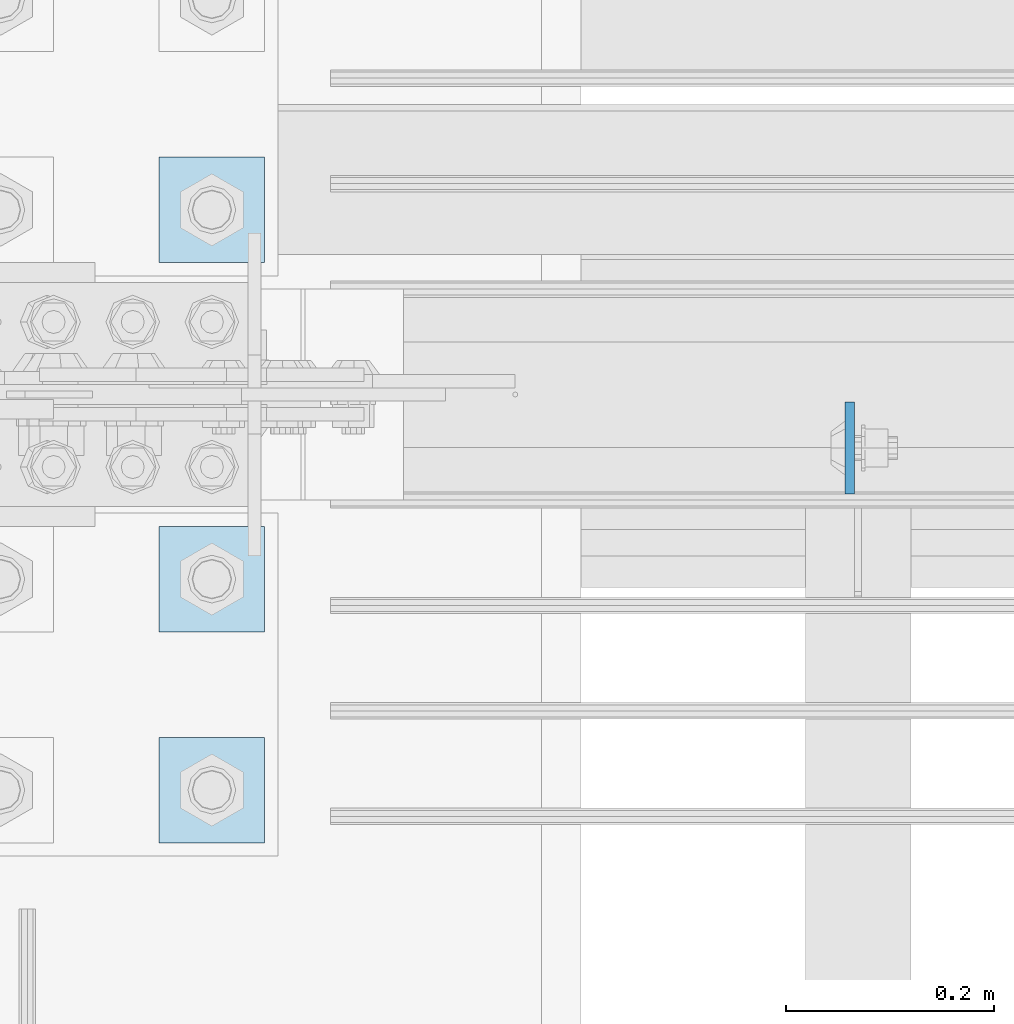
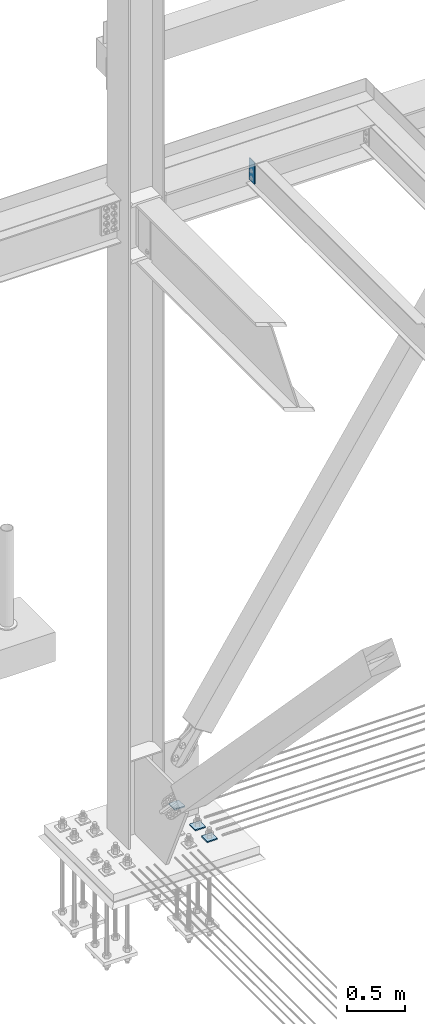
# One storey, part 3642 of 3843: 4 plates, 2 elements without a shape of their own.
"""IFC2X3 building model written with IfcOpenShell, lengths in millimetres."""

import ifcopenshell
import ifcopenshell.guid

model = None  # the IFC model being written
_history = None  # IfcOwnerHistory: only IFC2X3 demands one
_inside = {}  # id of a spatial element -> (the spatial element, [elements in it])
_under = {}  # id of a project, library or spatial element -> (it, [spatial elements below it])
_declared = {}  # id of a project -> (the project, [libraries it declares])
_typed = {}  # id of a type object -> (the type object, [elements of that type])
_made_of = {}  # id of a material, layer set ... -> (it, [elements and type objects made of it])


def new_model(schema):
    """Start an empty IFC model of exactly this schema.

    Asked for "IFC4X3", IfcOpenShell would pick the latest addendum, in which some entities
    have other attributes; the version numbers below select the first issue.
    IFC2X3 requires an IfcOwnerHistory on every rooted entity: one is made here for all.
    """
    global model, _history
    if schema == "IFC4X3":
        model = ifcopenshell.file(schema_version=(4, 3, 0, 0))
    else:
        model = ifcopenshell.file(schema=schema)
    _inside.clear()
    _under.clear()
    _declared.clear()
    _typed.clear()
    _made_of.clear()
    _history = None
    if model.schema == "IFC2X3":
        org = make("IfcOrganization", Name="unknown")
        user = make(
            "IfcPersonAndOrganization",
            ThePerson=make("IfcPerson", FamilyName="unknown"),
            TheOrganization=org,
        )
        app = make(
            "IfcApplication",
            ApplicationDeveloper=org,
            Version="unknown",
            ApplicationFullName="unknown",
            ApplicationIdentifier="unknown",
        )
        _history = make(
            "IfcOwnerHistory",
            OwningUser=user,
            OwningApplication=app,
            ChangeAction="ADDED",
            CreationDate=0,
        )
    return model


def make(cls, **values):
    """One entity of the class cls with the attributes given. An attribute that is None is left unset."""
    return model.create_entity(
        cls, **{name: value for name, value in values.items() if value is not None}
    )


def rooted(cls, **values):
    """An entity with a GlobalId (a new one), such as an element, a storey or a relation."""
    return make(cls, GlobalId=ifcopenshell.guid.new(), OwnerHistory=_history, **values)


def si_unit(unit_type, name, prefix=None):
    """IfcSIUnit, for example si_unit("LENGTHUNIT", "METRE", prefix="MILLI")."""
    return make("IfcSIUnit", UnitType=unit_type, Prefix=prefix, Name=name)


def assignment(units):
    """IfcUnitAssignment: the units of a project."""
    return None if units is None else make("IfcUnitAssignment", Units=units)


def point(xyz):
    """IfcCartesianPoint."""
    return None if xyz is None else make("IfcCartesianPoint", Coordinates=xyz)


def direction(xyz):
    """IfcDirection."""
    return None if xyz is None else make("IfcDirection", DirectionRatios=xyz)


def frame(location, z_axis=None, x_axis=None):
    """IfcAxis2Placement3D, a coordinate frame: its origin and axes. An axis left out is left unset."""
    return make(
        "IfcAxis2Placement3D",
        Location=point(location),
        Axis=direction(z_axis),
        RefDirection=direction(x_axis),
    )


def origin_with_axes():
    """The frame at (0, 0, 0) with the z axis (0, 0, 1) and the x axis (1, 0, 0) written out."""
    return frame((0.0, 0.0, 0.0), z_axis=(0.0, 0.0, 1.0), x_axis=(1.0, 0.0, 0.0))


def place(relative_to, where):
    """IfcLocalPlacement: puts the frame where relative to a parent placement (None: the world)."""
    return make(
        "IfcLocalPlacement", PlacementRelTo=relative_to, RelativePlacement=where
    )


def context(
    kind, dimensions, precision=None, world=None, true_north=None, identifier=None
):
    """IfcGeometricRepresentationContext, for example the 3D "Model" context."""
    return make(
        "IfcGeometricRepresentationContext",
        ContextIdentifier=identifier,
        ContextType=kind,
        CoordinateSpaceDimension=dimensions,
        Precision=precision,
        WorldCoordinateSystem=world,
        TrueNorth=true_north,
    )


def subcontext(parent, identifier, kind, view, scale=None):
    """IfcGeometricRepresentationSubContext, for example "Body" below "Model"."""
    return make(
        "IfcGeometricRepresentationSubContext",
        ContextIdentifier=identifier,
        ContextType=kind,
        ParentContext=parent,
        TargetScale=scale,
        TargetView=view,
    )


def project(units=None, contexts=None):
    """IfcProject with its units and contexts."""
    return rooted(
        "IfcProject",
        Name="project",
        RepresentationContexts=contexts,
        UnitsInContext=assignment(units),
    )


def spatial(cls, under=None, at=None, **own):
    """A site, building, storey or space (cls), placed at a placement, below another one or the project."""
    s = rooted(cls, ObjectPlacement=at, **own)
    if under is not None:
        _under.setdefault(under.id(), (under, []))[1].append(s)
    return s


def faces_of(points, faces, orient=None, outer=None):
    """IfcFace entities. A face is a list of loops; a loop is a list of indices into points, from 0.

    orient and outer hold one flag for each loop. By default every Orientation is true, the
    first loop of a face is its IfcFaceOuterBound and the others are IfcFaceBound.
    """
    made = []
    for i, loops in enumerate(faces):
        bounds = []
        for j, loop in enumerate(loops):
            is_outer = j == 0 if outer is None else outer[i][j]
            bounds.append(
                make(
                    "IfcFaceOuterBound" if is_outer else "IfcFaceBound",
                    Bound=make("IfcPolyLoop", Polygon=[points[k] for k in loop]),
                    Orientation=True if orient is None else orient[i][j],
                )
            )
        made.append(make("IfcFace", Bounds=bounds))
    return made


def faceted_brep(points, faces, orient=None, outer=None, voids=None):
    """IfcFacetedBrep: a solid bounded by flat faces; with voids (closed shells), ...WithVoids."""
    shared = [point(p) for p in points]
    hull = make("IfcClosedShell", CfsFaces=faces_of(shared, faces, orient, outer))
    if voids is None:
        return make("IfcFacetedBrep", Outer=hull)
    return make(
        "IfcFacetedBrepWithVoids",
        Outer=hull,
        Voids=[
            make(cls, CfsFaces=faces_of(shared, fs, o, b)) for cls, fs, o, b in voids
        ],
    )


def shape(context_of_items, identifier, shape_type, items):
    """IfcShapeRepresentation: the items that make up one representation, for example the "Body"."""
    return make(
        "IfcShapeRepresentation",
        ContextOfItems=context_of_items,
        RepresentationIdentifier=identifier,
        RepresentationType=shape_type,
        Items=items,
    )


def material(Name=None, Category=None):
    """IfcMaterial."""
    return make("IfcMaterial", Name=Name, Category=Category)


def made_of(thing, what):
    """Note that an element or type object is made of a material, layer set ...; save() writes the relation."""
    if what is not None:
        _made_of.setdefault(what.id(), (what, []))[1].append(thing)
    return thing


def type_object(cls, material=None, **own):
    """A type object (cls), such as IfcWallType, which elements share."""
    return made_of(rooted(cls, **own), material)


def element(
    cls,
    number,
    at=None,
    inside=None,
    cuts=None,
    type_object=None,
    material=None,
    context=None,
    identifier="Body",
    shape_type=None,
    held_by="IfcProductDefinitionShape",
    body=None,
    shapes=None,
    **own,
):
    """One element of the class cls, such as IfcWall. Its Tag is "e" and its number.

    at: its placement. inside: the storey or other place that contains it. cuts: it is an
    opening in that element (IfcRelVoidsElement). A single representation is given by context,
    identifier, shape_type and body (its items); several are given by shapes. held_by: the class
    of the entity that holds the representations. save() writes the other relations.
    """
    e = rooted(cls, Tag="e%d" % number, ObjectPlacement=at, **own)
    if body is not None:
        shapes = [shape(context, identifier, shape_type, body)]
    if shapes is not None:
        e.Representation = make(held_by, Representations=shapes)
    if inside is not None:
        _inside.setdefault(inside.id(), (inside, []))[1].append(e)
    if cuts is not None:
        rooted(
            "IfcRelVoidsElement", RelatingBuildingElement=cuts, RelatedOpeningElement=e
        )
    if type_object is not None:
        _typed.setdefault(type_object.id(), (type_object, []))[1].append(e)
    return made_of(e, material)


def aggregate(whole, parts):
    """IfcRelAggregates: a whole, such as a stair, and the parts it consists of."""
    return rooted("IfcRelAggregates", RelatingObject=whole, RelatedObjects=parts)


def save(model, path):
    """Write the relations noted so far, then the file.

    IfcRelAggregates (storeys below a building ...), IfcRelContainedInSpatialStructure (elements
    in a storey), IfcRelDefinesByType, IfcRelAssociatesMaterial and IfcRelDeclares: one each for
    every whole, place, type object, material and project.
    """
    for whole, parts in _under.values():
        aggregate(whole, parts)
    for where, things in _inside.values():
        rooted(
            "IfcRelContainedInSpatialStructure",
            RelatedElements=things,
            RelatingStructure=where,
        )
    for kind, things in _typed.values():
        rooted("IfcRelDefinesByType", RelatedObjects=things, RelatingType=kind)
    for what, things in _made_of.values():
        rooted("IfcRelAssociatesMaterial", RelatedObjects=things, RelatingMaterial=what)
    for by, libraries in _declared.values():
        rooted("IfcRelDeclares", RelatingContext=by, RelatedDefinitions=libraries)
    model.write(path)


model = new_model("IFC2X3")

# Units and contexts
model_context = context("Model", 3, precision=1e-05, world=origin_with_axes())
body_context = subcontext(model_context, "Body", "Model", "MODEL_VIEW")
ifc_project = project(units=[si_unit("LENGTHUNIT", "METRE", prefix="MILLI"), si_unit("AREAUNIT", "SQUARE_METRE"), si_unit("VOLUMEUNIT", "CUBIC_METRE"), si_unit("MASSUNIT", "GRAM", prefix="KILO"), si_unit("TIMEUNIT", "SECOND"), si_unit("PLANEANGLEUNIT", "RADIAN"), si_unit("SOLIDANGLEUNIT", "STERADIAN"), si_unit("THERMODYNAMICTEMPERATUREUNIT", "DEGREE_CELSIUS"), si_unit("LUMINOUSINTENSITYUNIT", "LUMEN")], contexts=[model_context])

# Site, building, storey
site_placement = place(None, origin_with_axes())
site = spatial("IfcSite", under=ifc_project, at=site_placement, CompositionType="ELEMENT")
building_placement = place(site_placement, origin_with_axes())
building = spatial("IfcBuilding", under=site, at=building_placement, Name="Undefined", CompositionType="ELEMENT")
storey_placement = place(building_placement, origin_with_axes())
storey = spatial("IfcBuildingStorey", under=building, at=storey_placement, Name="Undefined", CompositionType="ELEMENT", Elevation=0.0)

# Assembly, plate
assembly_1_placement = place(storey_placement, origin_with_axes())
assembly_1 = element("IfcElementAssembly", 1, at=assembly_1_placement, inside=storey, Name="BEAM", AssemblyPlace="NOTDEFINED", PredefinedType="RIGID_FRAME")
ifc_material = material(Name="STEEL/A572-50")
plate_type_1 = type_object("IfcPlateType", PredefinedType="NOTDEFINED")
plate_1_placement = place(assembly_1_placement, frame((78135.1625, 104551.95625, 36379.15), z_axis=(0.0, -1.0, 0.0), x_axis=(0.0, 0.0, -1.0)))
plate_1 = element("IfcPlate", 2, at=plate_1_placement, type_object=plate_type_1, material=ifc_material, Name="PLATE", context=body_context, shape_type="Brep", body=[
    faceted_brep([(0.0, -4.76249999999709, 0.0), (0.0, -4.76249999999709, 88.9000015258789), (0.0, 4.76249999999709, 88.9000015258789), (0.0, 4.76249999999709, 0.0), (228.600006102781, -4.7625000004191, 88.9000015257589), (228.600006102781, 4.76249999954598, 88.9000015257443), (228.600006103079, -4.7625000004482, 7.27595761418343e-12), (228.600006103079, 4.76249999954598, -7.27595761418343e-12)], [[[0, 1, 2, 3]], [[1, 4, 5, 2]], [[4, 6, 7, 5]], [[6, 0, 3, 7]], [[5, 7, 3, 2]], [[6, 4, 1, 0]]]),
])
aggregate(assembly_1, [plate_1])

# Assembly, plates
assembly_2_placement = place(storey_placement, origin_with_axes())
assembly_2 = element("IfcElementAssembly", 3, at=assembly_2_placement, inside=storey, Name="TEMPLATE", AssemblyPlace="NOTDEFINED", PredefinedType="RIGID_FRAME")
plate_type_2 = type_object("IfcPlateType", PredefinedType="NOTDEFINED")
plate_2_placement = place(assembly_2_placement, frame((77470.0, 104228.9, 29698.95), z_axis=(0.0, -1.0, 0.0), x_axis=(1.0, 0.0, 0.0)))
plate_2 = element("IfcPlate", 4, at=plate_2_placement, type_object=plate_type_2, material=ifc_material, Name="Washer Plate", context=body_context, shape_type="Brep", body=[
    faceted_brep([(0.0, -6.3499999046162, 0.0), (-1.67347025126219e-10, -6.35000000000582, 101.600000000151), (-1.67347025126219e-10, 6.35000000000582, 101.600000000151), (7.27595761418343e-12, 6.3499999046162, 0.0), (101.599998474121, -6.34999999999854, 101.599998474121), (101.599998474121, 6.34999999999854, 101.599998474121), (101.6, -6.34999999999854, 0.0), (101.6, 6.34999999999854, 0.0)], [[[0, 1, 2, 3]], [[1, 4, 5, 2]], [[4, 6, 7, 5]], [[6, 0, 3, 7]], [[5, 7, 3, 2]], [[6, 4, 1, 0]]]),
])
plate_3_placement = place(assembly_2_placement, frame((77470.0, 104432.1, 29698.95), z_axis=(0.0, -1.0, 0.0), x_axis=(1.0, 0.0, 0.0)))
plate_3 = element("IfcPlate", 5, at=plate_3_placement, type_object=plate_type_2, material=ifc_material, Name="Washer Plate", context=body_context, shape_type="Brep", body=[
    faceted_brep([(0.0, -6.3499999046162, 0.0), (-1.67347025126219e-10, -6.35000000000582, 101.600000000151), (-1.67347025126219e-10, 6.35000000000582, 101.600000000151), (7.27595761418343e-12, 6.3499999046162, 0.0), (101.599998474121, -6.34999999999854, 101.599998474121), (101.599998474121, 6.34999999999854, 101.599998474121), (101.6, -6.34999999999854, 0.0), (101.6, 6.34999999999854, 0.0)], [[[0, 1, 2, 3]], [[1, 4, 5, 2]], [[4, 6, 7, 5]], [[6, 0, 3, 7]], [[5, 7, 3, 2]], [[6, 4, 1, 0]]]),
])
plate_4_placement = place(assembly_2_placement, frame((77470.0, 104787.7, 29698.95), z_axis=(0.0, -1.0, 0.0), x_axis=(1.0, 0.0, 0.0)))
plate_4 = element("IfcPlate", 6, at=plate_4_placement, type_object=plate_type_2, material=ifc_material, Name="Washer Plate", context=body_context, shape_type="Brep", body=[
    faceted_brep([(0.0, -6.3499999046162, 0.0), (-1.67347025126219e-10, -6.35000000000582, 101.600000000151), (-1.67347025126219e-10, 6.35000000000582, 101.600000000151), (7.27595761418343e-12, 6.3499999046162, 0.0), (101.599998474121, -6.34999999999854, 101.599998474121), (101.599998474121, 6.34999999999854, 101.599998474121), (101.6, -6.34999999999854, 0.0), (101.6, 6.34999999999854, 0.0)], [[[0, 1, 2, 3]], [[1, 4, 5, 2]], [[4, 6, 7, 5]], [[6, 0, 3, 7]], [[5, 7, 3, 2]], [[6, 4, 1, 0]]]),
])
aggregate(assembly_2, [plate_2, plate_3, plate_4])

save(model, "model.ifc")
